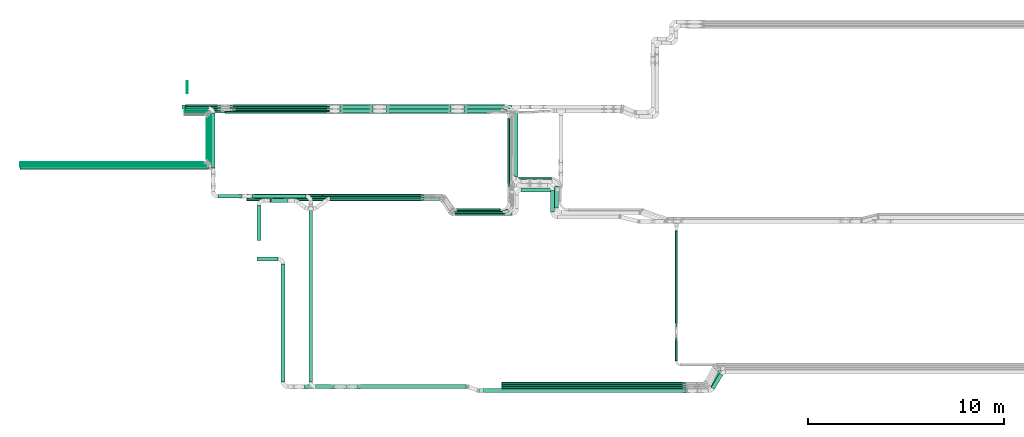
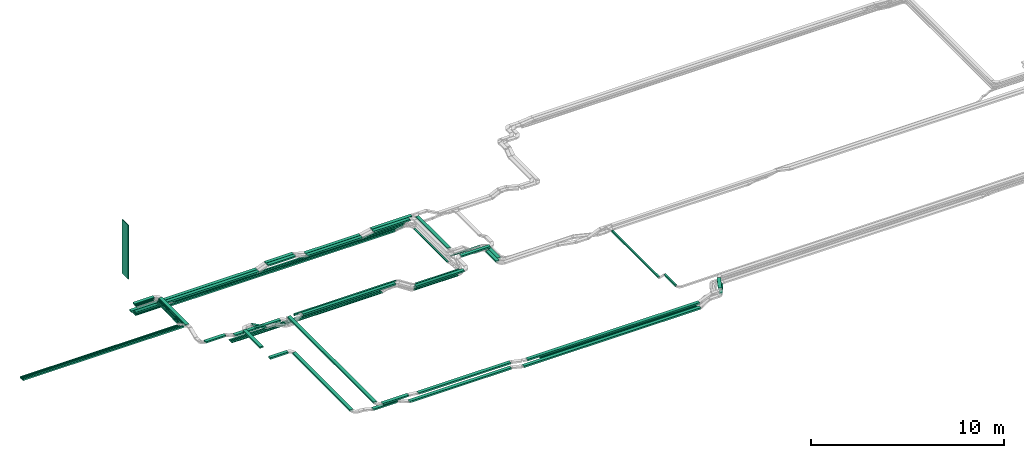
# One storey, part 1 of 25: 66 flow segments.
"""IFC2X3 building model written with IfcOpenShell, lengths in millimetres."""

import ifcopenshell
import ifcopenshell.guid

model = None  # the IFC model being written
_history = None  # IfcOwnerHistory: only IFC2X3 demands one
_inside = {}  # id of a spatial element -> (the spatial element, [elements in it])
_under = {}  # id of a project, library or spatial element -> (it, [spatial elements below it])
_declared = {}  # id of a project -> (the project, [libraries it declares])
_typed = {}  # id of a type object -> (the type object, [elements of that type])
_made_of = {}  # id of a material, layer set ... -> (it, [elements and type objects made of it])


def new_model(schema):
    """Start an empty IFC model of exactly this schema.

    Asked for "IFC4X3", IfcOpenShell would pick the latest addendum, in which some entities
    have other attributes; the version numbers below select the first issue.
    IFC2X3 requires an IfcOwnerHistory on every rooted entity: one is made here for all.
    """
    global model, _history
    if schema == "IFC4X3":
        model = ifcopenshell.file(schema_version=(4, 3, 0, 0))
    else:
        model = ifcopenshell.file(schema=schema)
    _inside.clear()
    _under.clear()
    _declared.clear()
    _typed.clear()
    _made_of.clear()
    _history = None
    if model.schema == "IFC2X3":
        org = make("IfcOrganization", Name="unknown")
        user = make(
            "IfcPersonAndOrganization",
            ThePerson=make("IfcPerson", FamilyName="unknown"),
            TheOrganization=org,
        )
        app = make(
            "IfcApplication",
            ApplicationDeveloper=org,
            Version="unknown",
            ApplicationFullName="unknown",
            ApplicationIdentifier="unknown",
        )
        _history = make(
            "IfcOwnerHistory",
            OwningUser=user,
            OwningApplication=app,
            ChangeAction="ADDED",
            CreationDate=0,
        )
    return model


def make(cls, **values):
    """One entity of the class cls with the attributes given. An attribute that is None is left unset."""
    return model.create_entity(
        cls, **{name: value for name, value in values.items() if value is not None}
    )


def entity(cls, *values):
    """Any entity or typed value of the class cls, its attributes in the order of the schema. None: left unset."""
    e = model.create_entity(cls)
    for i, value in enumerate(values):
        if value is not None:
            e[i] = value
    return e


def rooted(cls, **values):
    """An entity with a GlobalId (a new one), such as an element, a storey or a relation."""
    return make(cls, GlobalId=ifcopenshell.guid.new(), OwnerHistory=_history, **values)


def si_unit(unit_type, name, prefix=None):
    """IfcSIUnit, for example si_unit("LENGTHUNIT", "METRE", prefix="MILLI")."""
    return make("IfcSIUnit", UnitType=unit_type, Prefix=prefix, Name=name)


def converted_unit(unit_type, name, factor, base, dimensions=None, offset=None):
    """IfcConversionBasedUnit, such as the inch: factor (a typed value) times the base unit."""
    return make(
        "IfcConversionBasedUnit"
        if offset is None
        else "IfcConversionBasedUnitWithOffset",
        ConversionOffset=offset,
        Dimensions=None
        if dimensions is None
        else entity("IfcDimensionalExponents", *dimensions),
        UnitType=unit_type,
        Name=name,
        ConversionFactor=make(
            "IfcMeasureWithUnit", ValueComponent=factor, UnitComponent=base
        ),
    )


def derived_unit(unit_type, elements):
    """IfcDerivedUnit: a product of units, each with its exponent."""
    return make(
        "IfcDerivedUnit",
        Elements=[
            make("IfcDerivedUnitElement", Unit=unit, Exponent=power)
            for unit, power in elements
        ],
        UnitType=unit_type,
    )


def assignment(units):
    """IfcUnitAssignment: the units of a project."""
    return None if units is None else make("IfcUnitAssignment", Units=units)


def point(xyz):
    """IfcCartesianPoint."""
    return None if xyz is None else make("IfcCartesianPoint", Coordinates=xyz)


def direction(xyz):
    """IfcDirection."""
    return None if xyz is None else make("IfcDirection", DirectionRatios=xyz)


def frame(location, z_axis=None, x_axis=None):
    """IfcAxis2Placement3D, a coordinate frame: its origin and axes. An axis left out is left unset."""
    return make(
        "IfcAxis2Placement3D",
        Location=point(location),
        Axis=direction(z_axis),
        RefDirection=direction(x_axis),
    )


def frame_2d(location, x_axis=None):
    """IfcAxis2Placement2D, a coordinate frame in the plane: its origin and x axis."""
    return make(
        "IfcAxis2Placement2D", Location=point(location), RefDirection=direction(x_axis)
    )


def origin():
    """The frame at (0, 0, 0) with its axes left unset."""
    return frame((0.0, 0.0, 0.0))


def origin_2d_with_axis():
    """The frame at (0, 0) in the plane with the x axis (1, 0) written out."""
    return frame_2d((0.0, 0.0), x_axis=(1.0, 0.0))


def place(relative_to, where):
    """IfcLocalPlacement: puts the frame where relative to a parent placement (None: the world)."""
    return make(
        "IfcLocalPlacement", PlacementRelTo=relative_to, RelativePlacement=where
    )


def context(
    kind, dimensions, precision=None, world=None, true_north=None, identifier=None
):
    """IfcGeometricRepresentationContext, for example the 3D "Model" context."""
    return make(
        "IfcGeometricRepresentationContext",
        ContextIdentifier=identifier,
        ContextType=kind,
        CoordinateSpaceDimension=dimensions,
        Precision=precision,
        WorldCoordinateSystem=world,
        TrueNorth=true_north,
    )


def subcontext(parent, identifier, kind, view, scale=None):
    """IfcGeometricRepresentationSubContext, for example "Body" below "Model"."""
    return make(
        "IfcGeometricRepresentationSubContext",
        ContextIdentifier=identifier,
        ContextType=kind,
        ParentContext=parent,
        TargetScale=scale,
        TargetView=view,
    )


def project(units=None, contexts=None):
    """IfcProject with its units and contexts."""
    return rooted(
        "IfcProject",
        Name="project",
        RepresentationContexts=contexts,
        UnitsInContext=assignment(units),
    )


def spatial(cls, under=None, at=None, **own):
    """A site, building, storey or space (cls), placed at a placement, below another one or the project."""
    s = rooted(cls, ObjectPlacement=at, **own)
    if under is not None:
        _under.setdefault(under.id(), (under, []))[1].append(s)
    return s


def profile(cls, at=None, kind="AREA", **sizes):
    """A parametric profile (cls). Its sizes go by their IFC names, for example OverallWidth=200.0."""
    return make(cls, ProfileType=kind, Position=at, **sizes)


def rectangle(**sizes):
    """IfcRectangleProfileDef."""
    return profile("IfcRectangleProfileDef", **sizes)


def extrude(swept, where, along, depth):
    """IfcExtrudedAreaSolid: the profile swept, set in the frame where, extruded along a direction by depth."""
    return make(
        "IfcExtrudedAreaSolid",
        SweptArea=swept,
        Position=where,
        ExtrudedDirection=direction(along),
        Depth=depth,
    )


def shape(context_of_items, identifier, shape_type, items):
    """IfcShapeRepresentation: the items that make up one representation, for example the "Body"."""
    return make(
        "IfcShapeRepresentation",
        ContextOfItems=context_of_items,
        RepresentationIdentifier=identifier,
        RepresentationType=shape_type,
        Items=items,
    )


def made_of(thing, what):
    """Note that an element or type object is made of a material, layer set ...; save() writes the relation."""
    if what is not None:
        _made_of.setdefault(what.id(), (what, []))[1].append(thing)
    return thing


def type_object(cls, material=None, **own):
    """A type object (cls), such as IfcWallType, which elements share."""
    return made_of(rooted(cls, **own), material)


def element(
    cls,
    number,
    at=None,
    inside=None,
    cuts=None,
    type_object=None,
    material=None,
    context=None,
    identifier="Body",
    shape_type=None,
    held_by="IfcProductDefinitionShape",
    body=None,
    shapes=None,
    **own,
):
    """One element of the class cls, such as IfcWall. Its Tag is "e" and its number.

    at: its placement. inside: the storey or other place that contains it. cuts: it is an
    opening in that element (IfcRelVoidsElement). A single representation is given by context,
    identifier, shape_type and body (its items); several are given by shapes. held_by: the class
    of the entity that holds the representations. save() writes the other relations.
    """
    e = rooted(cls, Tag="e%d" % number, ObjectPlacement=at, **own)
    if body is not None:
        shapes = [shape(context, identifier, shape_type, body)]
    if shapes is not None:
        e.Representation = make(held_by, Representations=shapes)
    if inside is not None:
        _inside.setdefault(inside.id(), (inside, []))[1].append(e)
    if cuts is not None:
        rooted(
            "IfcRelVoidsElement", RelatingBuildingElement=cuts, RelatedOpeningElement=e
        )
    if type_object is not None:
        _typed.setdefault(type_object.id(), (type_object, []))[1].append(e)
    return made_of(e, material)


def aggregate(whole, parts):
    """IfcRelAggregates: a whole, such as a stair, and the parts it consists of."""
    return rooted("IfcRelAggregates", RelatingObject=whole, RelatedObjects=parts)


def save(model, path):
    """Write the relations noted so far, then the file.

    IfcRelAggregates (storeys below a building ...), IfcRelContainedInSpatialStructure (elements
    in a storey), IfcRelDefinesByType, IfcRelAssociatesMaterial and IfcRelDeclares: one each for
    every whole, place, type object, material and project.
    """
    for whole, parts in _under.values():
        aggregate(whole, parts)
    for where, things in _inside.values():
        rooted(
            "IfcRelContainedInSpatialStructure",
            RelatedElements=things,
            RelatingStructure=where,
        )
    for kind, things in _typed.values():
        rooted("IfcRelDefinesByType", RelatedObjects=things, RelatingType=kind)
    for what, things in _made_of.values():
        rooted("IfcRelAssociatesMaterial", RelatedObjects=things, RelatingMaterial=what)
    for by, libraries in _declared.values():
        rooted("IfcRelDeclares", RelatingContext=by, RelatedDefinitions=libraries)
    model.write(path)


model = new_model("IFC2X3")

# Units and contexts
model_context = context("Model", 3, precision=0.01, world=origin(), true_north=direction((6.12303176911189e-17, 1.0)))
body_context = subcontext(model_context, "Body", "Model", "MODEL_VIEW")
ifc_project = project(units=[si_unit("LENGTHUNIT", "METRE", prefix="MILLI"), si_unit("AREAUNIT", "SQUARE_METRE"), si_unit("VOLUMEUNIT", "CUBIC_METRE"), converted_unit("PLANEANGLEUNIT", "DEGREE", entity("IfcRatioMeasure", 0.0174532925199433), si_unit("PLANEANGLEUNIT", "RADIAN"), dimensions=[0, 0, 0, 0, 0, 0, 0]), si_unit("MASSUNIT", "GRAM", prefix="KILO"), derived_unit("MASSDENSITYUNIT", [(si_unit("MASSUNIT", "GRAM", prefix="KILO"), 1), (si_unit("LENGTHUNIT", "METRE"), -3)]), derived_unit("MOMENTOFINERTIAUNIT", [(si_unit("LENGTHUNIT", "METRE"), 4)]), si_unit("TIMEUNIT", "SECOND"), si_unit("FREQUENCYUNIT", "HERTZ"), si_unit("THERMODYNAMICTEMPERATUREUNIT", "DEGREE_CELSIUS"), derived_unit("THERMALTRANSMITTANCEUNIT", [(si_unit("MASSUNIT", "GRAM", prefix="KILO"), 1), (si_unit("THERMODYNAMICTEMPERATUREUNIT", "KELVIN"), -1), (si_unit("TIMEUNIT", "SECOND"), -3)]), derived_unit("VOLUMETRICFLOWRATEUNIT", [(si_unit("LENGTHUNIT", "METRE"), 3), (si_unit("TIMEUNIT", "SECOND"), -1)]), derived_unit("MASSFLOWRATEUNIT", [(si_unit("MASSUNIT", "GRAM", prefix="KILO"), 1), (si_unit("TIMEUNIT", "SECOND"), -1)]), derived_unit("ROTATIONALFREQUENCYUNIT", [(si_unit("TIMEUNIT", "SECOND"), -1)]), si_unit("ELECTRICCURRENTUNIT", "AMPERE"), si_unit("ELECTRICVOLTAGEUNIT", "VOLT"), si_unit("POWERUNIT", "WATT"), si_unit("FORCEUNIT", "NEWTON", prefix="KILO"), si_unit("ILLUMINANCEUNIT", "LUX"), si_unit("LUMINOUSFLUXUNIT", "LUMEN"), si_unit("LUMINOUSINTENSITYUNIT", "CANDELA"), derived_unit("USERDEFINED", [(si_unit("MASSUNIT", "GRAM", prefix="KILO"), -1), (si_unit("LENGTHUNIT", "METRE"), -2), (si_unit("TIMEUNIT", "SECOND"), 3), (si_unit("LUMINOUSFLUXUNIT", "LUMEN"), 1)]), derived_unit("LINEARVELOCITYUNIT", [(si_unit("LENGTHUNIT", "METRE"), 1), (si_unit("TIMEUNIT", "SECOND"), -1)]), si_unit("PRESSUREUNIT", "PASCAL"), derived_unit("USERDEFINED", [(si_unit("LENGTHUNIT", "METRE"), -2), (si_unit("MASSUNIT", "GRAM", prefix="KILO"), 1), (si_unit("TIMEUNIT", "SECOND"), -2)]), derived_unit("LINEARFORCEUNIT", [(si_unit("MASSUNIT", "GRAM", prefix="KILO"), 1), (si_unit("LENGTHUNIT", "METRE"), 1), (si_unit("TIMEUNIT", "SECOND"), -2), (si_unit("LENGTHUNIT", "METRE"), -1)]), derived_unit("PLANARFORCEUNIT", [(si_unit("MASSUNIT", "GRAM", prefix="KILO"), 1), (si_unit("LENGTHUNIT", "METRE"), 1), (si_unit("TIMEUNIT", "SECOND"), -2), (si_unit("LENGTHUNIT", "METRE"), -2)])], contexts=[model_context])

# Site, building, storey
site_placement = place(None, frame((0.0, -0.00077364408347762, 0.0)))
site = spatial("IfcSite", under=ifc_project, at=site_placement, CompositionType="ELEMENT")
building_placement = place(site_placement, origin())
building = spatial("IfcBuilding", under=site, at=building_placement, CompositionType="ELEMENT")
storey_placement = place(building_placement, frame((0.0, 0.0, 24000.0)))
storey = spatial("IfcBuildingStorey", under=building, at=storey_placement, CompositionType="ELEMENT", Elevation=24000.0)

# Flow segments
cable_carrier_segment_type_1 = type_object("IfcCableCarrierSegmentType", PredefinedType="CABLETRAYSEGMENT")
flow_segment_1_placement = place(storey_placement, frame((18426.2408475987, 14367.8235638227, 2650.0)))
element("IfcFlowSegment", 1, at=flow_segment_1_placement, inside=storey, type_object=cable_carrier_segment_type_1, context=body_context, shape_type="SweptSolid", body=[
    extrude(rectangle(XDim=13495.0496959612, YDim=99.9999999999989, at=frame_2d((-1.36424205265939e-12, -1.08357767203415e-12), x_axis=(1.0, 0.0))), frame((6747.5248479806, 50.0, 0.0), z_axis=(0.0, 0.0, 1.0), x_axis=(-1.0, 0.0, 0.0)), (0.0, 0.0, 1.0), 100.000000000003),
])
flow_segment_2_placement = place(storey_placement, frame((20056.2408475987, 6814.77664183531, 3300.0)))
element("IfcFlowSegment", 2, at=flow_segment_2_placement, inside=storey, type_object=cable_carrier_segment_type_1, context=body_context, shape_type="SweptSolid", body=[
    extrude(rectangle(XDim=1067.73986382415, YDim=200.0, at=origin_2d_with_axis()), frame((533.869931912073, 100.0, 0.0)), (0.0, 0.0, 1.0), 100.000000000003),
])
flow_segment_3_placement = place(storey_placement, frame((21274.9807114228, 666.0, 3300.0)))
element("IfcFlowSegment", 3, at=flow_segment_3_placement, inside=storey, type_object=cable_carrier_segment_type_1, context=body_context, shape_type="SweptSolid", body=[
    extrude(rectangle(XDim=5997.77664183526, YDim=199.999999999998, at=frame_2d((-6.82121026329696e-13, 2.16715534406831e-12), x_axis=(1.0, 0.0))), frame((100.0, 2998.88832091763, 0.0), z_axis=(0.0, 0.0, 1.0), x_axis=(0.0, -1.0, 0.0)), (0.0, 0.0, 1.0), 100.000000000003),
])
flow_segment_4_placement = place(storey_placement, frame((16218.7969712117, 14577.8235638228, 2900.0)))
element("IfcFlowSegment", 4, at=flow_segment_4_placement, inside=storey, type_object=cable_carrier_segment_type_1, context=body_context, shape_type="SweptSolid", body=[
    extrude(rectangle(XDim=7528.07147672482, YDim=200.000000000002, at=frame_2d((-1.13686837721616e-12, 0.0), x_axis=(1.0, 0.0))), frame((3764.03573836241, 100.0, 0.0), z_axis=(0.0, 0.0, 1.0), x_axis=(-1.0, 0.0, 0.0)), (0.0, 0.0, 1.0), 100.000000000003),
])
flow_segment_5_placement = place(storey_placement, frame((19782.0608420285, 10024.9425362387, 2890.0)))
element("IfcFlowSegment", 5, at=flow_segment_5_placement, inside=storey, type_object=cable_carrier_segment_type_1, context=body_context, shape_type="SweptSolid", body=[
    extrude(rectangle(XDim=2751.91986939437, YDim=199.999999999998, at=frame_2d((0.0, 1.08002495835535e-12), x_axis=(1.0, 0.0))), frame((1375.95993469719, 100.0, 0.0), z_axis=(0.0, 0.0, 1.0), x_axis=(-1.0, 0.0, 0.0)), (0.0, 0.0, 1.0), 99.9999999999989),
])
flow_segment_6_placement = place(storey_placement, frame((33153.0827924389, 11137.9003960974, 3040.0)))
element("IfcFlowSegment", 6, at=flow_segment_6_placement, inside=storey, type_object=cable_carrier_segment_type_1, context=body_context, shape_type="SweptSolid", body=[
    extrude(rectangle(XDim=3309.92316772541, YDim=199.999999999998, at=frame_2d((-1.02318153949454e-12, -4.33431068813661e-12), x_axis=(1.0, 0.0))), frame((100.0, 1654.96158386271, 0.0), z_axis=(0.0, 0.0, 1.0), x_axis=(0.0, 1.0, 0.0)), (0.0, 0.0, 1.0), 100.000000000003),
])
flow_segment_7_placement = place(storey_placement, frame((16371.7335612672, 14382.4130642905, 3340.0)))
element("IfcFlowSegment", 7, at=flow_segment_7_placement, inside=storey, type_object=cable_carrier_segment_type_1, context=body_context, shape_type="SweptSolid", body=[
    extrude(rectangle(XDim=1072.92022544604, YDim=50.0000000000016, at=frame_2d((0.0, -1.08357767203415e-12), x_axis=(1.0, 0.0))), frame((536.460112723021, 25.0, 0.0)), (0.0, 0.0, 1.0), 49.9999999999973),
])
flow_segment_8_placement = place(storey_placement, frame((17595.6537867132, 11880.4288730807, 3340.0)))
element("IfcFlowSegment", 8, at=flow_segment_8_placement, inside=storey, type_object=cable_carrier_segment_type_1, context=body_context, shape_type="SweptSolid", body=[
    extrude(rectangle(XDim=2350.98419120989, YDim=50.0000000000016, at=frame_2d((1.02318153949454e-12, -1.08357767203415e-12), x_axis=(1.0, 0.0))), frame((25.0, 1175.49209560494, 0.0), z_axis=(0.0, 0.0, 1.0), x_axis=(0.0, 1.0, 0.0)), (0.0, 0.0, 1.0), 49.9999999999973),
])
flow_segment_9_placement = place(storey_placement, frame((7960.65378671321, 11679.4288730807, 3340.0)))
element("IfcFlowSegment", 9, at=flow_segment_9_placement, inside=storey, type_object=cable_carrier_segment_type_1, context=body_context, shape_type="SweptSolid", body=[
    extrude(rectangle(XDim=9484.00000000001, YDim=50.0000000000016, at=frame_2d((0.0, 1.08357767203415e-12), x_axis=(1.0, 0.0))), frame((4742.0, 25.0, 0.0), z_axis=(0.0, 0.0, 1.0), x_axis=(-1.0, 0.0, 0.0)), (0.0, 0.0, 1.0), 49.9999999999973),
])
flow_segment_10_placement = place(storey_placement, frame((16371.7335612672, 14447.7421886283, 3340.0)))
element("IfcFlowSegment", 10, at=flow_segment_10_placement, inside=storey, type_object=cable_carrier_segment_type_1, context=body_context, shape_type="SweptSolid", body=[
    extrude(rectangle(XDim=1151.41871774957, YDim=50.0000000000016, at=frame_2d((0.0, -1.08357767203415e-12), x_axis=(1.0, 0.0))), frame((575.709358874786, 25.0, 0.0)), (0.0, 0.0, 1.0), 49.9999999999973),
])
flow_segment_11_placement = place(storey_placement, frame((17653.1522790167, 11820.4288730807, 3340.0)))
element("IfcFlowSegment", 11, at=flow_segment_11_placement, inside=storey, type_object=cable_carrier_segment_type_1, context=body_context, shape_type="SweptSolid", body=[
    extrude(rectangle(XDim=2497.31331554762, YDim=50.0000000000016, at=frame_2d((0.0, -1.08357767203415e-12), x_axis=(1.0, 0.0))), frame((25.0, 1248.65665777381, 0.0), z_axis=(0.0, 0.0, 1.0), x_axis=(0.0, 1.0, 0.0)), (0.0, 0.0, 1.0), 49.9999999999973),
])
flow_segment_12_placement = place(storey_placement, frame((7960.65378671321, 11619.4288730807, 3340.0)))
element("IfcFlowSegment", 12, at=flow_segment_12_placement, inside=storey, type_object=cable_carrier_segment_type_1, context=body_context, shape_type="SweptSolid", body=[
    extrude(rectangle(XDim=9541.49849230354, YDim=50.0000000000016, at=frame_2d((9.09494701772928e-13, 0.0), x_axis=(1.0, 0.0))), frame((4770.74924615177, 25.0, 0.0), z_axis=(0.0, 0.0, 1.0), x_axis=(-1.0, 0.0, 0.0)), (0.0, 0.0, 1.0), 49.9999999999973),
])
flow_segment_13_placement = place(storey_placement, frame((16371.7335612672, 14322.4130642905, 3340.0)))
element("IfcFlowSegment", 13, at=flow_segment_13_placement, inside=storey, type_object=cable_carrier_segment_type_1, context=body_context, shape_type="SweptSolid", body=[
    extrude(rectangle(XDim=1033.92022544605, YDim=50.0000000000016, at=frame_2d((1.08002495835535e-12, -1.08357767203415e-12), x_axis=(1.0, 0.0))), frame((516.960112723021, 25.0, 0.0)), (0.0, 0.0, 1.0), 49.9999999999973),
])
flow_segment_14_placement = place(storey_placement, frame((17535.6537867132, 11940.4288730807, 3340.0)))
element("IfcFlowSegment", 14, at=flow_segment_14_placement, inside=storey, type_object=cable_carrier_segment_type_1, context=body_context, shape_type="SweptSolid", body=[
    extrude(rectangle(XDim=2251.98419120988, YDim=50.0000000000016, at=frame_2d((0.0, -1.08357767203415e-12), x_axis=(1.0, 0.0))), frame((25.0, 1125.99209560494, 0.0), z_axis=(0.0, 0.0, 1.0), x_axis=(0.0, 1.0, 0.0)), (0.0, 0.0, 1.0), 49.9999999999973),
])
flow_segment_15_placement = place(storey_placement, frame((7960.65378671321, 11739.4288730807, 3340.0)))
element("IfcFlowSegment", 15, at=flow_segment_15_placement, inside=storey, type_object=cable_carrier_segment_type_1, context=body_context, shape_type="SweptSolid", body=[
    extrude(rectangle(XDim=9424.00000000001, YDim=50.0000000000016, at=frame_2d((-1.36424205265939e-12, 1.08357767203415e-12), x_axis=(1.0, 0.0))), frame((4712.0, 25.0, 0.0), z_axis=(0.0, 0.0, 1.0), x_axis=(-1.0, 0.0, 0.0)), (0.0, 0.0, 1.0), 49.9999999999973),
])
flow_segment_16_placement = place(storey_placement, frame((17475.6537867132, 12000.4288730807, 3340.0)))
element("IfcFlowSegment", 16, at=flow_segment_16_placement, inside=storey, type_object=cable_carrier_segment_type_1, context=body_context, shape_type="SweptSolid", body=[
    extrude(rectangle(XDim=2131.98419120988, YDim=50.0000000000016, at=frame_2d((1.13686837721616e-12, -1.08357767203415e-12), x_axis=(1.0, 0.0))), frame((25.0, 1065.99209560494, 0.0), z_axis=(0.0, 0.0, 1.0), x_axis=(0.0, 1.0, 0.0)), (0.0, 0.0, 1.0), 49.9999999999973),
])
flow_segment_17_placement = place(storey_placement, frame((7960.65378671321, 11799.4288730807, 3340.0)))
element("IfcFlowSegment", 17, at=flow_segment_17_placement, inside=storey, type_object=cable_carrier_segment_type_1, context=body_context, shape_type="SweptSolid", body=[
    extrude(rectangle(XDim=9364.00000000001, YDim=50.0000000000016, at=frame_2d((9.09494701772928e-13, -1.08357767203415e-12), x_axis=(1.0, 0.0))), frame((4682.0, 25.0, 0.0), z_axis=(0.0, 0.0, 1.0), x_axis=(-1.0, 0.0, 0.0)), (0.0, 0.0, 1.0), 49.9999999999973),
])
flow_segment_18_placement = place(storey_placement, frame((26641.019481577, 14367.8235638228, 2900.0)))
element("IfcFlowSegment", 18, at=flow_segment_18_placement, inside=storey, type_object=cable_carrier_segment_type_1, context=body_context, shape_type="SweptSolid", body=[
    extrude(rectangle(XDim=3294.43505749826, YDim=200.000000000002, at=frame_2d((0.0, 1.08713038571295e-12), x_axis=(1.0, 0.0))), frame((1647.21752874913, 100.0, 0.0)), (0.0, 0.0, 1.0), 100.000000000003),
])
flow_segment_19_placement = place(storey_placement, frame((23395.4635612722, 10107.8235638227, 2890.0)))
element("IfcFlowSegment", 19, at=flow_segment_19_placement, inside=storey, type_object=cable_carrier_segment_type_1, context=body_context, shape_type="SweptSolid", body=[
    extrude(rectangle(XDim=6113.97273683925, YDim=99.9999999999989, at=frame_2d((-2.27373675443232e-12, 1.08357767203415e-12), x_axis=(1.0, 0.0))), frame((3056.98636841963, 50.0, 0.0), z_axis=(0.0, 0.0, 1.0), x_axis=(-1.0, 0.0, 0.0)), (0.0, 0.0, 1.0), 100.000000000003),
])
flow_segment_20_placement = place(storey_placement, frame((41375.1084711671, 3498.35676369398, 2970.0)))
element("IfcFlowSegment", 20, at=flow_segment_20_placement, inside=storey, type_object=cable_carrier_segment_type_1, context=body_context, shape_type="SweptSolid", body=[
    extrude(rectangle(XDim=4876.63246763186, YDim=99.9999999999946, at=origin_2d_with_axis()), frame((50.0, 2438.31623381593, 0.0), z_axis=(0.0, 0.0, 1.0), x_axis=(0.0, -1.0, 0.0)), (0.0, 0.0, 1.0), 100.000000000003),
])
flow_segment_21_placement = place(storey_placement, frame((7960.65378671321, 11509.4288730807, 3340.0)))
element("IfcFlowSegment", 21, at=flow_segment_21_placement, inside=storey, type_object=cable_carrier_segment_type_1, context=body_context, shape_type="SweptSolid", body=[
    extrude(rectangle(XDim=9622.49849230355, YDim=99.9999999999989, at=frame_2d((0.0, -1.08357767203415e-12), x_axis=(1.0, 0.0))), frame((4811.24924615177, 50.0, 0.0), z_axis=(0.0, 0.0, 1.0), x_axis=(-1.0, 0.0, 0.0)), (0.0, 0.0, 1.0), 100.000000000003),
])
flow_segment_22_placement = place(storey_placement, frame((16371.7335612672, 14507.7421886283, 3340.0)))
element("IfcFlowSegment", 22, at=flow_segment_22_placement, inside=storey, type_object=cable_carrier_segment_type_1, context=body_context, shape_type="SweptSolid", body=[
    extrude(rectangle(XDim=1190.41871774959, YDim=200.000000000002, at=frame_2d((1.08002495835535e-12, 0.0), x_axis=(1.0, 0.0))), frame((595.209358874795, 100.0, 0.0), z_axis=(0.0, 0.0, 1.0), x_axis=(-1.0, 0.0, 0.0)), (0.0, 0.0, 1.0), 100.000000000003),
])
flow_segment_23_placement = place(storey_placement, frame((17713.1522790168, 11560.4205151585, 3340.0)))
element("IfcFlowSegment", 23, at=flow_segment_23_placement, inside=storey, type_object=cable_carrier_segment_type_1, context=body_context, shape_type="SweptSolid", body=[
    extrude(rectangle(XDim=2796.32167346978, YDim=199.999999999998, at=frame_2d((-1.02318153949454e-12, 1.08002495835535e-12), x_axis=(1.0, 0.0))), frame((100.0, 1398.16083673489, 0.0), z_axis=(0.0, 0.0, 1.0), x_axis=(0.0, -1.0, 0.0)), (0.0, 0.0, 1.0), 100.000000000003),
])
flow_segment_24_placement = place(storey_placement, frame((18043.1522790167, 10024.9425362387, 3074.68104404424)))
element("IfcFlowSegment", 24, at=flow_segment_24_placement, inside=storey, type_object=cable_carrier_segment_type_1, context=body_context, shape_type="SweptSolid", body=[
    extrude(rectangle(XDim=1199.60118000453, YDim=200.000000000002, at=origin_2d_with_axis()), frame((599.800590002263, 100.0, 0.0)), (0.0, 0.0, 1.0), 100.000000000003),
])
flow_segment_25_placement = place(storey_placement, frame((22684.9807114228, 665.942525090682, 3299.99775904745)))
element("IfcFlowSegment", 25, at=flow_segment_25_placement, inside=storey, type_object=cable_carrier_segment_type_1, context=body_context, shape_type="SweptSolid", body=[
    extrude(rectangle(XDim=8953.99998500641, YDim=199.999999999998, at=frame_2d((9.09494701772928e-13, 2.16715534406831e-12), x_axis=(1.0, 0.0))), frame((100.0, 4477.00001737455, 0.00111349630326458), z_axis=(0.0, -2.48714832989699e-07, 1.0), x_axis=(0.0, -1.0, -2.48714832989699e-07)), (0.0, 0.0, 1.0), 99.9999999999976),
])
flow_segment_26_placement = place(storey_placement, frame((25180.0956006173, 315.0, 3225.21024639395)))
element("IfcFlowSegment", 26, at=flow_segment_26_placement, inside=storey, type_object=cable_carrier_segment_type_1, context=body_context, shape_type="SweptSolid", body=[
    extrude(rectangle(XDim=5524.45942997487, YDim=200.0, at=origin_2d_with_axis()), frame((2762.22971498744, 100.0, 0.0)), (0.0, 0.0, 1.0), 100.000000000003),
])
flow_segment_27_placement = place(storey_placement, frame((16371.7335612672, 14367.8235638228, 2900.0)))
element("IfcFlowSegment", 27, at=flow_segment_27_placement, inside=storey, type_object=cable_carrier_segment_type_1, context=body_context, shape_type="SweptSolid", body=[
    extrude(rectangle(XDim=7374.99679891814, YDim=200.000000000002, at=origin_2d_with_axis()), frame((3687.49839945907, 100.0, 0.0)), (0.0, 0.0, 1.0), 100.000000000003),
])
flow_segment_28_placement = place(storey_placement, frame((24291.9954944818, 14577.8235638228, 3120.0)))
element("IfcFlowSegment", 28, at=flow_segment_28_placement, inside=storey, type_object=cable_carrier_segment_type_1, context=body_context, shape_type="SweptSolid", body=[
    extrude(rectangle(XDim=1637.51555642012, YDim=200.000000000002, at=frame_2d((0.0, -2.16715534406831e-12), x_axis=(1.0, 0.0))), frame((818.757778210061, 100.0, 0.0), z_axis=(0.0, 0.0, 1.0), x_axis=(-1.0, 0.0, 0.0)), (0.0, 0.0, 1.0), 100.000000000003),
])
flow_segment_29_placement = place(storey_placement, frame((24285.0701722885, 14367.8235638228, 3120.0)))
element("IfcFlowSegment", 29, at=flow_segment_29_placement, inside=storey, type_object=cable_carrier_segment_type_1, context=body_context, shape_type="SweptSolid", body=[
    extrude(rectangle(XDim=1637.37746866894, YDim=200.000000000002, at=origin_2d_with_axis()), frame((818.688734334472, 100.0, 0.0)), (0.0, 0.0, 1.0), 100.000000000003),
])
flow_segment_30_placement = place(storey_placement, frame((26648.0828915214, 14577.8235638228, 2900.0)))
element("IfcFlowSegment", 30, at=flow_segment_30_placement, inside=storey, type_object=cable_carrier_segment_type_1, context=body_context, shape_type="SweptSolid", body=[
    extrude(rectangle(XDim=3294.44624764002, YDim=200.000000000002, at=frame_2d((2.1600499167107e-12, -1.08713038571295e-12), x_axis=(1.0, 0.0))), frame((1647.22312382001, 100.0, 0.0)), (0.0, 0.0, 1.0), 100.000000000003),
])
flow_segment_31_placement = place(storey_placement, frame((24652.9597539772, 315.0, 2875.21024639399)))
element("IfcFlowSegment", 31, at=flow_segment_31_placement, inside=storey, type_object=cable_carrier_segment_type_1, context=body_context, shape_type="SweptSolid", body=[
    extrude(rectangle(XDim=6091.36072683295, YDim=200.0, at=frame_2d((-4.32009983342141e-12, 3.5527136788005e-14), x_axis=(1.0, 0.0))), frame((3045.68036341648, 100.0, 0.0)), (0.0, 0.0, 1.0), 100.000000000003),
])
flow_segment_32_placement = place(storey_placement, frame((22469.2503154781, 315.0, 3150.0)))
element("IfcFlowSegment", 32, at=flow_segment_32_placement, inside=storey, type_object=cable_carrier_segment_type_1, context=body_context, shape_type="SweptSolid", body=[
    extrude(rectangle(XDim=1469.63189251783, YDim=200.0, at=frame_2d((0.0, -3.5527136788005e-14), x_axis=(1.0, 0.0))), frame((734.815946258926, 100.0, 0.0)), (0.0, 0.0, 1.0), 100.000000000003),
])
flow_segment_33_placement = place(storey_placement, frame((23035.9807114228, 314.913822160891, 3299.94030355077)))
element("IfcFlowSegment", 33, at=flow_segment_33_placement, inside=storey, type_object=cable_carrier_segment_type_1, context=body_context, shape_type="SweptSolid", body=[
    extrude(rectangle(XDim=200.0, YDim=1559.04216988274, at=frame_2d((2.21689333557151e-12, 0.0), x_axis=(0.0, 1.0))), frame((779.521084941374, 100.057447241461, 0.0574637519045041), z_axis=(0.0, -0.000574637518698523, 0.999999834895847), x_axis=(1.0, 0.0, 0.0)), (0.0, 0.0, 1.0), 100.000000000004),
])
flow_segment_34_placement = place(storey_placement, frame((32519.4016711439, 539.999226355414, 2875.210246394)))
element("IfcFlowSegment", 34, at=flow_segment_34_placement, inside=storey, type_object=cable_carrier_segment_type_1, context=body_context, shape_type="SweptSolid", body=[
    extrude(rectangle(XDim=9371.15824609092, YDim=100.0, at=frame_2d((0.0, 6.75015598972095e-14), x_axis=(1.0, 0.0))), frame((4685.57912304546, 50.0, 0.0)), (0.0, 0.0, 1.0), 49.9999999999973),
])
flow_segment_35_placement = place(storey_placement, frame((32519.4016711439, 429.999226355414, 2875.210246394)))
element("IfcFlowSegment", 35, at=flow_segment_35_placement, inside=storey, type_object=cable_carrier_segment_type_1, context=body_context, shape_type="SweptSolid", body=[
    extrude(rectangle(XDim=9371.15824609092, YDim=100.0, at=frame_2d((0.0, 3.19744231092045e-14), x_axis=(1.0, 0.0))), frame((4685.57912304546, 50.0, 0.0)), (0.0, 0.0, 1.0), 49.9999999999973),
])
flow_segment_36_placement = place(storey_placement, frame((31591.0203352076, 109.999226355427, 3225.21024639401)))
element("IfcFlowSegment", 36, at=flow_segment_36_placement, inside=storey, type_object=cable_carrier_segment_type_1, context=body_context, shape_type="SweptSolid", body=[
    extrude(rectangle(XDim=10314.9035127911, YDim=200.0, at=frame_2d((2.27373675443232e-12, 0.0), x_axis=(1.0, 0.0))), frame((5157.45175639552, 100.0, 0.0)), (0.0, 0.0, 1.0), 100.000000000003),
])
flow_segment_37_placement = place(storey_placement, frame((32519.4016711439, 319.999226355414, 2875.210246394)))
element("IfcFlowSegment", 37, at=flow_segment_37_placement, inside=storey, type_object=cable_carrier_segment_type_1, context=body_context, shape_type="SweptSolid", body=[
    extrude(rectangle(XDim=9371.15824609091, YDim=100.0, at=frame_2d((0.0, 3.19744231092045e-14), x_axis=(1.0, 0.0))), frame((4685.57912304545, 50.0, 0.0)), (0.0, 0.0, 1.0), 49.9999999999973),
])
flow_segment_38_placement = place(storey_placement, frame((31381.2725511012, 109.999226355426, 2875.21024639399)))
element("IfcFlowSegment", 38, at=flow_segment_38_placement, inside=storey, type_object=cable_carrier_segment_type_1, context=body_context, shape_type="SweptSolid", body=[
    extrude(rectangle(XDim=10596.2476289759, YDim=200.0, at=frame_2d((1.81898940354586e-12, 1.4210854715202e-14), x_axis=(1.0, 0.0))), frame((5298.12381448795, 100.0, 0.0)), (0.0, 0.0, 1.0), 100.000000000003),
])
flow_segment_39_placement = place(storey_placement, frame((23778.0876894373, 9897.82356382274, 2890.0)))
element("IfcFlowSegment", 39, at=flow_segment_39_placement, inside=storey, type_object=cable_carrier_segment_type_1, context=body_context, shape_type="SweptSolid", body=[
    extrude(rectangle(XDim=5565.86907921064, YDim=200.000000000002, at=frame_2d((2.04636307898909e-12, 0.0), x_axis=(1.0, 0.0))), frame((2782.93453960532, 100.0, 0.0), z_axis=(0.0, 0.0, 1.0), x_axis=(-1.0, 0.0, 0.0)), (0.0, 0.0, 1.0), 100.000000000003),
])
flow_segment_40_placement = place(storey_placement, frame((30125.6991068742, 9147.82356382267, 2890.0)))
element("IfcFlowSegment", 40, at=flow_segment_40_placement, inside=storey, type_object=cable_carrier_segment_type_1, context=body_context, shape_type="SweptSolid", body=[
    extrude(rectangle(XDim=2909.1864182489, YDim=200.0, at=frame_2d((2.1600499167107e-12, 5.47117906535277e-13), x_axis=(1.0, 0.0))), frame((1454.59320912445, 100.0, 0.0)), (0.0, 0.0, 1.0), 100.000000000003),
])
flow_segment_41_placement = place(storey_placement, frame((20036.8706665486, 7874.71703990355, 3351.74219071095)))
element("IfcFlowSegment", 41, at=flow_segment_41_placement, inside=storey, type_object=cable_carrier_segment_type_1, context=body_context, shape_type="SweptSolid", body=[
    extrude(rectangle(XDim=1776.94785004133, YDim=199.999999999998, at=frame_2d((-5.11590769747272e-13, 0.0), x_axis=(1.0, 0.0))), frame((100.0, 888.473925020668, 0.0), z_axis=(0.0, 0.0, 1.0), x_axis=(0.0, 1.0, 0.0)), (0.0, 0.0, 1.0), 100.000000000003),
])
flow_segment_42_placement = place(storey_placement, frame((20706.0638655211, 9802.6648899449, 2902.84517517821)))
element("IfcFlowSegment", 42, at=flow_segment_42_placement, inside=storey, type_object=cable_carrier_segment_type_1, context=body_context, shape_type="SweptSolid", body=[
    extrude(rectangle(XDim=100.0, YDim=200.000000000002, at=frame_2d((0.0, 0.0), x_axis=(0.0, 1.0))), frame((23.6523467191816, 100.0, 491.999978933289), z_axis=(0.881037228424638, 0.0, -0.473046934383717), x_axis=(0.0, 1.0, 0.0)), (0.0, 0.0, 1.0), 946.942226981447),
])
flow_segment_43_placement = place(storey_placement, frame((30163.8562855468, 9376.10783662937, 2750.0)))
element("IfcFlowSegment", 43, at=flow_segment_43_placement, inside=storey, type_object=cable_carrier_segment_type_1, context=body_context, shape_type="SweptSolid", body=[
    extrude(rectangle(XDim=2289.22650689214, YDim=99.9999999999989, at=origin_2d_with_axis()), frame((1144.61325344607, 50.0, 0.0)), (0.0, 0.0, 1.0), 49.9999999999973),
])
flow_segment_44_placement = place(storey_placement, frame((30095.9730497845, 9266.10783662938, 2750.0)))
element("IfcFlowSegment", 44, at=flow_segment_44_placement, inside=storey, type_object=cable_carrier_segment_type_1, context=body_context, shape_type="SweptSolid", body=[
    extrude(rectangle(XDim=2467.10974265438, YDim=99.9999999999989, at=frame_2d((-4.32009983342141e-12, 0.0), x_axis=(1.0, 0.0))), frame((1233.5548713272, 50.0, 0.0)), (0.0, 0.0, 1.0), 49.9999999999973),
])
flow_segment_45_placement = place(storey_placement, frame((30008.5817383587, 9156.10783662936, 2750.0)))
element("IfcFlowSegment", 45, at=flow_segment_45_placement, inside=storey, type_object=cable_carrier_segment_type_1, context=body_context, shape_type="SweptSolid", body=[
    extrude(rectangle(XDim=2664.50105408022, YDim=100.000000000001, at=frame_2d((2.1600499167107e-12, -5.43565192856477e-13), x_axis=(1.0, 0.0))), frame((1332.25052704011, 50.0, 0.0)), (0.0, 0.0, 1.0), 49.9999999999973),
])
flow_segment_46_placement = place(storey_placement, frame((19519.4016711439, 9897.82356382278, 2650.0)))
element("IfcFlowSegment", 46, at=flow_segment_46_placement, inside=storey, type_object=cable_carrier_segment_type_1, context=body_context, shape_type="SweptSolid", body=[
    extrude(rectangle(XDim=9035.28773953544, YDim=99.9999999999989, at=frame_2d((0.0, 1.08357767203415e-12), x_axis=(1.0, 0.0))), frame((4517.64386976772, 50.0, 0.0)), (0.0, 0.0, 1.0), 50.0000000000016),
])
flow_segment_47_placement = place(storey_placement, frame((19519.4016697078, 10007.8235638228, 2650.0)))
element("IfcFlowSegment", 47, at=flow_segment_47_placement, inside=storey, type_object=cable_carrier_segment_type_1, context=body_context, shape_type="SweptSolid", body=[
    extrude(rectangle(XDim=9035.25711850963, YDim=99.9999999999989, at=frame_2d((0.0, 1.08357767203415e-12), x_axis=(1.0, 0.0))), frame((4517.62856212706, 50.0, 0.000259515171592284)), (0.0, 0.0, 1.0), 50.0000000000017),
])
flow_segment_48_placement = place(storey_placement, frame((19519.4016697186, 10117.8235638228, 2650.0)))
element("IfcFlowSegment", 48, at=flow_segment_48_placement, inside=storey, type_object=cable_carrier_segment_type_1, context=body_context, shape_type="SweptSolid", body=[
    extrude(rectangle(XDim=9035.33059198998, YDim=99.9999999999989, at=frame_2d((2.27373675443232e-12, 0.0), x_axis=(1.0, 0.0))), frame((4517.66529884573, 50.0, 0.000257574431134344)), (0.0, 0.0, 1.0), 50.0000000000017),
])
flow_segment_49_placement = place(storey_placement, frame((30609.7388998762, 14367.8235638228, 3040.0)))
element("IfcFlowSegment", 49, at=flow_segment_49_placement, inside=storey, type_object=cable_carrier_segment_type_1, context=body_context, shape_type="SweptSolid", body=[
    extrude(rectangle(XDim=2182.34389256264, YDim=200.000000000002, at=frame_2d((2.1600499167107e-12, 1.08713038571295e-12), x_axis=(1.0, 0.0))), frame((1091.17194628132, 100.0, 0.0), z_axis=(0.0, 0.0, 1.0), x_axis=(-1.0, 0.0, 0.0)), (0.0, 0.0, 1.0), 100.000000000003),
])
flow_segment_50_placement = place(storey_placement, frame((32833.0827924389, 10611.4765215059, 2650.0)))
element("IfcFlowSegment", 50, at=flow_segment_50_placement, inside=storey, type_object=cable_carrier_segment_type_1, context=body_context, shape_type="SweptSolid", body=[
    extrude(rectangle(XDim=3486.34704231681, YDim=100.000000000003, at=frame_2d((-1.02318153949454e-12, 0.0), x_axis=(1.0, 0.0))), frame((50.0, 1743.1735211584, 0.0), z_axis=(0.0, 0.0, 1.0), x_axis=(0.0, -1.0, 0.0)), (0.0, 0.0, 1.0), 49.9999999999973),
])
flow_segment_51_placement = place(storey_placement, frame((18785.3226386239, 14477.8235638227, 2650.0)))
element("IfcFlowSegment", 51, at=flow_segment_51_placement, inside=storey, type_object=cable_carrier_segment_type_1, context=body_context, shape_type="SweptSolid", body=[
    extrude(rectangle(XDim=13667.7601538151, YDim=99.9999999999989, at=origin_2d_with_axis()), frame((6833.88007690753, 50.0, 0.0), z_axis=(0.0, 0.0, 1.0), x_axis=(-1.0, 0.0, 0.0)), (0.0, 0.0, 1.0), 49.9999999999973),
])
flow_segment_52_placement = place(storey_placement, frame((16399.4016711439, 14587.8235638228, 2700.0)))
element("IfcFlowSegment", 52, at=flow_segment_52_placement, inside=storey, type_object=cable_carrier_segment_type_1, context=body_context, shape_type="SweptSolid", body=[
    extrude(rectangle(XDim=1797.44094448676, YDim=99.9999999999989, at=frame_2d((0.0, -2.16715534406831e-12), x_axis=(1.0, 0.0))), frame((898.720472243382, 50.0, 0.0), z_axis=(0.0, 0.0, 1.0), x_axis=(-1.0, 0.0, 0.0)), (0.0, 0.0, 1.0), 49.9999999999973),
])
flow_segment_53_placement = place(storey_placement, frame((16399.4016711439, 14697.8235638228, 2700.0)))
element("IfcFlowSegment", 53, at=flow_segment_53_placement, inside=storey, type_object=cable_carrier_segment_type_1, context=body_context, shape_type="SweptSolid", body=[
    extrude(rectangle(XDim=1797.44094448677, YDim=99.9999999999989, at=frame_2d((1.08002495835535e-12, 0.0), x_axis=(1.0, 0.0))), frame((898.720472243382, 50.0, 0.0), z_axis=(0.0, 0.0, 1.0), x_axis=(-1.0, 0.0, 0.0)), (0.0, 0.0, 1.0), 49.9999999999973),
])
flow_segment_54_placement = place(storey_placement, frame((30238.6650047575, 9357.82356382266, 2890.0)))
element("IfcFlowSegment", 54, at=flow_segment_54_placement, inside=storey, type_object=cable_carrier_segment_type_1, context=body_context, shape_type="SweptSolid", body=[
    extrude(rectangle(XDim=2603.41778768155, YDim=99.9999999999989, at=frame_2d((-2.1600499167107e-12, 0.0), x_axis=(1.0, 0.0))), frame((1301.70889384078, 50.0, 0.0)), (0.0, 0.0, 1.0), 100.000000000003),
])
flow_segment_55_placement = place(storey_placement, frame((33536.8855251231, 10347.8235638228, 2890.0)))
element("IfcFlowSegment", 55, at=flow_segment_55_placement, inside=storey, type_object=cable_carrier_segment_type_1, context=body_context, shape_type="SweptSolid", body=[
    extrude(rectangle(XDim=1747.73016943143, YDim=199.999999999998, at=frame_2d((0.0, 1.08002495835535e-12), x_axis=(1.0, 0.0))), frame((873.865084715716, 100.0, 0.0)), (0.0, 0.0, 1.0), 100.000000000003),
])
flow_segment_56_placement = place(storey_placement, frame((35013.0827924389, 9325.94253623849, 2660.0)))
element("IfcFlowSegment", 56, at=flow_segment_56_placement, inside=storey, type_object=cable_carrier_segment_type_1, context=body_context, shape_type="SweptSolid", body=[
    extrude(rectangle(XDim=1099.95785985898, YDim=199.999999999998, at=frame_2d((5.11590769747272e-13, 2.16715534406831e-12), x_axis=(1.0, 0.0))), frame((100.0, 549.978929929492, 0.0), z_axis=(0.0, 0.0, 1.0), x_axis=(0.0, -1.0, 0.0)), (0.0, 0.0, 1.0), 100.000000000003),
])
flow_segment_57_placement = place(storey_placement, frame((35223.0827924389, 9535.9425362385, 2660.0)))
element("IfcFlowSegment", 57, at=flow_segment_57_placement, inside=storey, type_object=cable_carrier_segment_type_1, context=body_context, shape_type="SweptSolid", body=[
    extrude(rectangle(XDim=1120.95785985897, YDim=199.999999999998, at=frame_2d((-5.6843418860808e-13, -2.16715534406831e-12), x_axis=(1.0, 0.0))), frame((100.0, 560.478929929487, 0.0), z_axis=(0.0, 0.0, 1.0), x_axis=(0.0, -1.0, 0.0)), (0.0, 0.0, 1.0), 100.000000000003),
])
flow_segment_58_placement = place(storey_placement, frame((33282.9701347114, 10996.9003960971, 2650.04120960501)))
element("IfcFlowSegment", 58, at=flow_segment_58_placement, inside=storey, type_object=cable_carrier_segment_type_1, context=body_context, shape_type="SweptSolid", body=[
    extrude(rectangle(XDim=49.9999999999973, YDim=99.9999999999989, at=origin_2d_with_axis()), frame((0.11265772753369, 50.0, 24.9997461634386), z_axis=(0.999989846537598, 0.0, 0.00450630910082806), x_axis=(-0.00450630910082806, 0.0, 0.999989846537598)), (0.0, 0.0, 1.0), 1780.02243937971),
])
flow_segment_59_placement = place(storey_placement, frame((41375.1084711671, 1730.69184714201, 3517.23038971969)))
element("IfcFlowSegment", 59, at=flow_segment_59_placement, inside=storey, type_object=cable_carrier_segment_type_1, context=body_context, shape_type="SweptSolid", body=[
    extrude(rectangle(XDim=1173.69946209604, YDim=99.9999999999946, at=frame_2d((-1.70530256582424e-13, -4.33075797445781e-12), x_axis=(1.0, 0.0))), frame((50.0, 586.849731048018, 0.0), z_axis=(0.0, 0.0, 1.0), x_axis=(0.0, -1.0, 0.0)), (0.0, 0.0, 1.0), 100.000000000008),
])
flow_segment_60_placement = place(storey_placement, frame((43195.9467607971, 281.31019100231, 3217.23038971969)))
element("IfcFlowSegment", 60, at=flow_segment_60_placement, inside=storey, type_object=cable_carrier_segment_type_1, context=body_context, shape_type="SweptSolid", body=[
    extrude(rectangle(XDim=832.336893352993, YDim=199.999999999996, at=frame_2d((5.6843418860808e-14, 3.5527136788005e-14), x_axis=(1.0, 0.0))), frame((299.330655091604, 408.535345746375, 0.0), z_axis=(0.0, 0.0, 1.0), x_axis=(-0.512992652430847, -0.85839299773004, 0.0)), (0.0, 0.0, 1.0), 100.000000000003),
])
flow_segment_61_placement = place(storey_placement, frame((43162.6852980067, 306.085802532153, 3517.23038971969)))
element("IfcFlowSegment", 61, at=flow_segment_61_placement, inside=storey, type_object=cable_carrier_segment_type_1, context=body_context, shape_type="SweptSolid", body=[
    extrude(rectangle(XDim=980.149325928577, YDim=200.000000000005, at=frame_2d((5.6843418860808e-14, 3.5527136788005e-14), x_axis=(1.0, 0.0))), frame((306.453393439696, 483.759734216538, 0.0), z_axis=(0.0, 0.0, 1.0), x_axis=(-0.442315095835614, -0.896859719240379, 0.0)), (0.0, 0.0, 1.0), 100.000000000003),
])
flow_segment_62_placement = place(storey_placement, frame((30629.631841352, 14577.8235638228, 3040.0)))
element("IfcFlowSegment", 62, at=flow_segment_62_placement, inside=storey, type_object=cable_carrier_segment_type_1, context=body_context, shape_type="SweptSolid", body=[
    extrude(rectangle(XDim=2393.45095108697, YDim=199.999999999998, at=frame_2d((-2.1600499167107e-12, 1.08002495835535e-12), x_axis=(1.0, 0.0))), frame((1196.72547554349, 100.0, 0.0)), (0.0, 0.0, 1.0), 100.000000000003),
])
flow_segment_63_placement = place(storey_placement, frame((16399.4016711439, 14477.8235638227, 2700.0)))
element("IfcFlowSegment", 63, at=flow_segment_63_placement, inside=storey, type_object=cable_carrier_segment_type_1, context=body_context, shape_type="SweptSolid", body=[
    extrude(rectangle(XDim=1797.76015381485, YDim=99.9999999999989, at=frame_2d((1.08002495835535e-12, 1.08357767203415e-12), x_axis=(1.0, 0.0))), frame((898.880076907428, 50.0, 0.0)), (0.0, 0.0, 1.0), 49.9999999999973),
])
flow_segment_64_placement = place(storey_placement, frame((18665.6418479518, 14587.8235638227, 2650.0)))
element("IfcFlowSegment", 64, at=flow_segment_64_placement, inside=storey, type_object=cable_carrier_segment_type_1, context=body_context, shape_type="SweptSolid", body=[
    extrude(rectangle(XDim=13897.4409444871, YDim=99.9999999999989, at=frame_2d((-2.27373675443232e-12, 0.0), x_axis=(1.0, 0.0))), frame((6948.72047224357, 50.0, 0.0), z_axis=(0.0, 0.0, 1.0), x_axis=(-1.0, 0.0, 0.0)), (0.0, 0.0, 1.0), 49.9999999999973),
])
flow_segment_65_placement = place(storey_placement, frame((18665.6418479518, 14697.8235638227, 2650.0)))
element("IfcFlowSegment", 65, at=flow_segment_65_placement, inside=storey, type_object=cable_carrier_segment_type_1, context=body_context, shape_type="SweptSolid", body=[
    extrude(rectangle(XDim=14007.4409444871, YDim=99.9999999999989, at=origin_2d_with_axis()), frame((7003.72047224357, 50.0, 0.0), z_axis=(0.0, 0.0, 1.0), x_axis=(-1.0, 0.0, 0.0)), (0.0, 0.0, 1.0), 49.9999999999973),
])
cable_carrier_segment_type_2 = type_object("IfcCableCarrierSegmentType", PredefinedType="CABLETRAYSEGMENT")
flow_segment_66_placement = place(storey_placement, frame((16472.305766128, 15387.6093717677, 4425.84199571756)))
element("IfcFlowSegment", 66, at=flow_segment_66_placement, inside=storey, type_object=cable_carrier_segment_type_2, context=body_context, shape_type="SweptSolid", body=[
    extrude(rectangle(XDim=50.0000000000016, YDim=599.999999999998, at=origin_2d_with_axis()), frame((25.0, 300.0, 0.0), z_axis=(0.0, 0.0, 1.0), x_axis=(-1.0, 0.0, 0.0)), (0.0, 0.0, 1.0), 3440.0),
])

save(model, "model.ifc")
